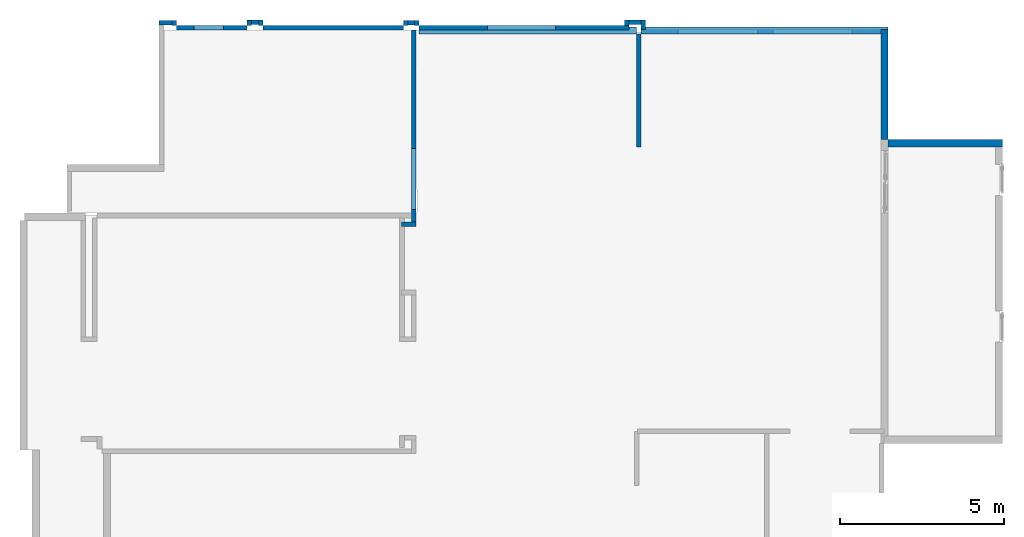
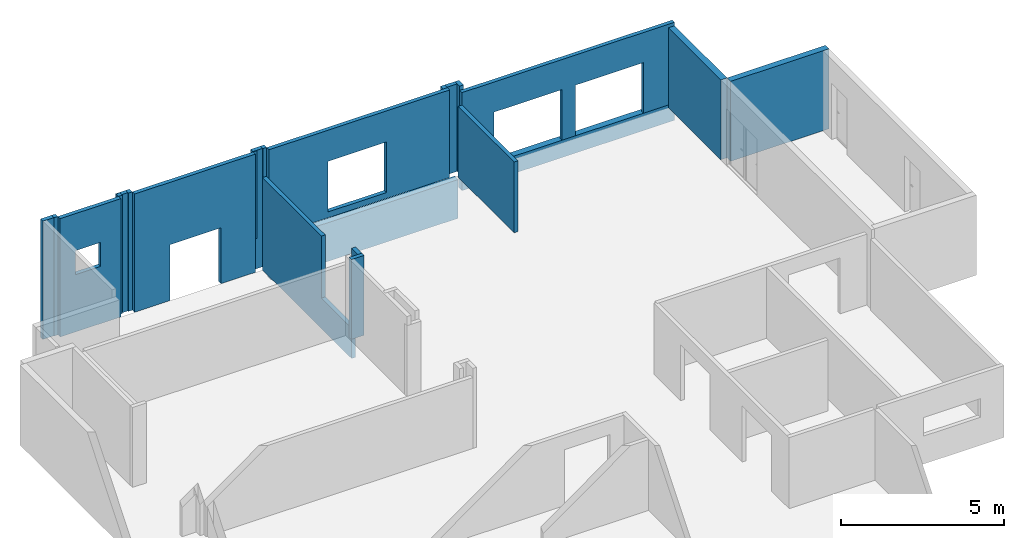
# One storey, part 3 of 4: 23 walls, 6 openings.
"""IFC4X3_ADD2 building model written with IfcOpenShell, lengths in millimetres."""

from ifc_helpers import new_model, entity, si_unit, converted_unit, frame, origin_with_axes, origin_2d_with_axis, place, context, subcontext, project, spatial, line, indexed_curve, outline, extrude, material, layer, layer_set, layer_usage, type_object, element, save


model = new_model("IFC4X3_ADD2")

# Units and contexts
model_context = context("Model", 3, precision=1e-05, world=origin_with_axes())
plan_context = context("Plan", 2, precision=1e-05, world=origin_2d_with_axis())
body_context = subcontext(model_context, "Body", "Model", "MODEL_VIEW")
ifc_project = project(units=[si_unit("VOLUMEUNIT", "CUBIC_METRE"), si_unit("LENGTHUNIT", "METRE", prefix="MILLI"), converted_unit("PLANEANGLEUNIT", "degree", entity("IfcReal", 0.0174532925199433), si_unit("PLANEANGLEUNIT", "RADIAN"), dimensions=[0, 0, 0, 0, 0, 0, 0]), si_unit("AREAUNIT", "SQUARE_METRE")], contexts=[model_context, plan_context])

# Site, building, storey
site_placement = place(None, origin_with_axes())
site = spatial("IfcSite", under=ifc_project, at=site_placement)
building_placement = place(site_placement, origin_with_axes())
building = spatial("IfcBuilding", under=site, at=building_placement, Name="Building")
storey_placement = place(building_placement, origin_with_axes())
storey = spatial("IfcBuildingStorey", under=building, at=storey_placement, Name="Storey")

# Walls
ifc_material_1 = material(Name="Clay_Brick_Red", Category="Bricks")
ifc_layer_1 = layer(ifc_material_1, 220.000015258789)
ifc_layer_set_1 = layer_set([ifc_layer_1])
ifc_layer_usage_1 = layer_usage(ifc_layer_set_1, "AXIS2", "POSITIVE", 0.0)
wall_type_1 = type_object("IfcWallType", Name="220mm_External", PredefinedType="STANDARD", material=ifc_layer_set_1)
wall_1_placement = place(storey_placement, frame((30176.3038635254, 36062.7861022949, 1145.0001001358), z_axis=(0.0, 0.0, 1.0), x_axis=(-0.999999999999098, -1.34308868382383e-06, 0.0)))
element("IfcWall", 1, at=wall_1_placement, inside=storey, type_object=wall_type_1, material=ifc_layer_usage_1, Name="Wall", context=body_context, shape_type="SweptSolid", body=[
    extrude(outline(indexed_curve([(0.0, 0.0), (0.0, 220.000015258789), (3500.00023841858, 220.000015258789), (3500.00023841858, 0.0)], segments=[line(1, 2, 3, 4, 1)])), origin_with_axes(), (0.0, 0.0, 1.0), 3000.0),
])
ifc_layer_usage_2 = layer_usage(ifc_layer_set_1, "AXIS2", "POSITIVE", 0.0)
wall_2_placement = place(storey_placement, frame((26456.3007354736, 39429.7828674316, 1145.0001001358), z_axis=(0.0, 0.0, 1.0), x_axis=(1.5060094256097e-06, -0.999999999998866, 0.0)))
element("IfcWall", 2, at=wall_2_placement, inside=storey, type_object=wall_type_1, material=ifc_layer_usage_2, Name="Wall", context=body_context, shape_type="SweptSolid", body=[
    extrude(outline(indexed_curve([(0.0, 0.0), (0.0, 220.000015258789), (3367.00010299683, 220.000015258789), (3367.00010299683, 0.0)], segments=[line(1, 2, 3, 4, 1)])), origin_with_axes(), (0.0, 0.0, 1.0), 3000.0),
])

# Wall, openings
ifc_material_2 = material(Category="Plastic")
ifc_layer_2 = layer(ifc_material_2, 140.0)
ifc_layer_set_2 = layer_set([ifc_layer_2])
ifc_layer_usage_3 = layer_usage(ifc_layer_set_2, "AXIS2", "POSITIVE", 0.0)
wall_type_2 = type_object("IfcWallType", Name="RDP", PredefinedType="ELEMENTEDWALL", material=ifc_layer_set_2)
wall_3_placement = place(storey_placement, frame((19126.3027191162, 39289.7758483887, 1145.0001001358), z_axis=(0.0, 0.0, 1.0), x_axis=(0.999999999998799, 1.5497207641583e-06, 0.0)))
wall_3 = element("IfcWall", 3, at=wall_3_placement, inside=storey, type_object=wall_type_2, material=ifc_layer_usage_3, Name="Wall", context=body_context, shape_type="SweptSolid", body=[
    extrude(outline(indexed_curve([(0.0, 0.0), (0.0, 140.0), (7550.00019073486, 140.0), (7550.00019073486, 0.0)], segments=[line(1, 2, 3, 4, 1)])), origin_with_axes(), (0.0, 0.0, 1.0), 3130.00011444092),
])
opening_1_placement = place(wall_3_placement, frame((1150.00917958512, 11707.9945862292, -1045.00009864569), z_axis=(0.0, 0.0, 1.0), x_axis=(0.999999999998799, -1.5497207641583e-06, 0.0)))
element("IfcOpeningElement", 4, at=opening_1_placement, cuts=wall_3, PredefinedType="OPENING", context=body_context, shape_type="SweptSolid", body=[
    extrude(outline(indexed_curve([(0.0, 499.999877929688), (2410.0, 499.999877929688), (2410.0, 0.0), (0.0, 0.0), (0.0, 499.999877929688)])), frame((0.00905990600585938, -11957.9925537109, 1145.0001001358), z_axis=(0.0, 0.0, 1.0), x_axis=(1.0, 0.0, 0.0)), (0.0, 0.0, 1.0), 1900.00012207031),
])
opening_2_placement = place(wall_3_placement, frame((4043.0088286295, 11707.9901028875, -1045.00009864569), z_axis=(0.0, 0.0, 1.0), x_axis=(0.999999999998799, -1.5497207641583e-06, 0.0)))
element("IfcOpeningElement", 5, at=opening_2_placement, cuts=wall_3, PredefinedType="OPENING", context=body_context, shape_type="SweptSolid", body=[
    extrude(outline(indexed_curve([(0.0, 499.999877929688), (2410.0, 499.999877929688), (2410.0, 0.0), (0.0, 0.0), (0.0, 499.999877929688)])), frame((0.00905990600585938, -11957.9925537109, 1145.0001001358), z_axis=(0.0, 0.0, 1.0), x_axis=(1.0, 0.0, 0.0)), (0.0, 0.0, 1.0), 1900.00012207031),
])

# Walls
ifc_layer_usage_4 = layer_usage(ifc_layer_set_2, "AXIS2", "POSITIVE", 0.0)
wall_4_placement = place(storey_placement, frame((19266.3173675537, 39429.7752380371, 1145.0001001358), z_axis=(0.0, 0.0, 1.0), x_axis=(-1.47422281315652e-06, 0.999999999998913, 0.0)))
element("IfcWall", 6, at=wall_4_placement, inside=storey, type_object=wall_type_2, material=ifc_layer_usage_4, Name="Wall", context=body_context, shape_type="SweptSolid", body=[
    extrude(outline(indexed_curve([(0.0, 0.0), (0.0, 140.0), (290.000021457672, 140.0), (290.000021457672, 0.0)], segments=[line(1, 2, 3, 4, 1)])), origin_with_axes(), (0.0, 0.0, 1.0), 3287.00017929077),
])
ifc_layer_usage_5 = layer_usage(ifc_layer_set_2, "AXIS2", "POSITIVE", 0.0)
wall_5_placement = place(storey_placement, frame((19126.3027191162, 39719.7761535645, 1145.0001001358), z_axis=(0.0, 0.0, 1.0), x_axis=(-0.999999999998344, -1.81992584202516e-06, 0.0)))
element("IfcWall", 7, at=wall_5_placement, inside=storey, type_object=wall_type_2, material=ifc_layer_usage_5, Name="Wall", context=body_context, shape_type="SweptSolid", body=[
    extrude(outline(indexed_curve([(0.0, 0.0), (0.0, 140.0), (503.000020980835, 140.0), (503.000020980835, 0.0)], segments=[line(1, 2, 3, 4, 1)])), origin_with_axes(), (0.0, 0.0, 1.0), 3287.00017929077),
])
ifc_layer_usage_6 = layer_usage(ifc_layer_set_2, "AXIS2", "POSITIVE", 0.0)
wall_6_placement = place(storey_placement, frame((18763.3037567139, 39549.7779846191, 1145.0001001358), z_axis=(0.0, 0.0, 1.0), x_axis=(-1.47422281315652e-06, 0.999999999998913, 0.0)))
element("IfcWall", 8, at=wall_6_placement, inside=storey, type_object=wall_type_2, material=ifc_layer_usage_6, Name="Wall", context=body_context, shape_type="SweptSolid", body=[
    extrude(outline(indexed_curve([(0.0, 0.0), (0.0, 140.0), (170.000001788139, 140.0), (170.000001788139, 0.0)], segments=[line(1, 2, 3, 4, 1)])), origin_with_axes(), (0.0, 0.0, 1.0), 3287.00017929077),
])

# Wall, opening
ifc_layer_usage_7 = layer_usage(ifc_layer_set_2, "AXIS2", "POSITIVE", 0.0)
wall_7_placement = place(storey_placement, frame((18763.3037567139, 39549.7779846191, 1145.0001001358), z_axis=(0.0, 0.0, 1.0), x_axis=(-0.999999999998344, -1.81992584202516e-06, 0.0)))
wall_7 = element("IfcWall", 9, at=wall_7_placement, inside=storey, type_object=wall_type_2, material=ifc_layer_usage_7, Name="Wall", context=body_context, shape_type="SweptSolid", body=[
    extrude(outline(indexed_curve([(0.0, 0.0), (0.0, 140.0), (6413.00010681152, 140.0), (6413.00010681152, 0.0)], segments=[line(1, 2, 3, 4, 1)])), origin_with_axes(), (0.0, 0.0, 1.0), 3287.00017929077),
])
opening_3_placement = place(wall_7_placement, frame((4324.0005592646, 250.0038496215, 220.000013709068), z_axis=(0.0, 0.0, 1.0), x_axis=(-0.999999999998458, 1.75635284449256e-06, 0.0)))
element("IfcOpeningElement", 10, at=opening_3_placement, cuts=wall_7, PredefinedType="OPENING", context=body_context, shape_type="SweptSolid", body=[
    extrude(outline(indexed_curve([(0.0, 0.0), (2079.15673828125, 0.0), (2079.15673828125, 499.999908447266), (0.0, 499.999908447266), (0.0, 0.0)])), origin_with_axes(), (0.0, 0.0, 1.0), 1900.00012207031),
])

# Walls
ifc_layer_usage_8 = layer_usage(ifc_layer_set_2, "AXIS2", "POSITIVE", 0.0)
wall_8_placement = place(storey_placement, frame((12210.3033065796, 39699.7680664062, 0.0), z_axis=(0.0, 0.0, 1.0), x_axis=(2.34047433877363e-06, -0.999999999997261, 0.0)))
element("IfcWall", 11, at=wall_8_placement, inside=storey, type_object=wall_type_2, material=ifc_layer_usage_8, Name="Wall", context=body_context, shape_type="SweptSolid", body=[
    extrude(outline(indexed_curve([(0.0, 0.0), (0.0, 140.0), (150.000005960464, 140.0), (150.000005960464, 0.0)], segments=[line(1, 2, 3, 4, 1)])), origin_with_axes(), (0.0, 0.0, 1.0), 4440.00005722046),
])
ifc_layer_usage_9 = layer_usage(ifc_layer_set_2, "AXIS2", "POSITIVE", 0.0)
wall_9_placement = place(storey_placement, frame((11868.3032989502, 39559.7686767578, 0.0), z_axis=(0.0, 0.0, 1.0), x_axis=(0.999999999997698, 2.14576721190912e-06, 0.0)))
element("IfcWall", 12, at=wall_9_placement, inside=storey, type_object=wall_type_2, material=ifc_layer_usage_9, Name="Wall", context=body_context, shape_type="SweptSolid", body=[
    extrude(outline(indexed_curve([(0.0, 0.0), (0.0, 140.0), (482.000023126602, 140.0), (482.000023126602, 0.0)], segments=[line(1, 2, 3, 4, 1)])), origin_with_axes(), (0.0, 0.0, 1.0), 4440.00005722046),
])
ifc_layer_usage_10 = layer_usage(ifc_layer_set_2, "AXIS2", "POSITIVE", 0.0)
wall_10_placement = place(storey_placement, frame((12008.3036422729, 39549.7665405273, 1145.0001001358), z_axis=(0.0, 0.0, 1.0), x_axis=(-2.1894786641444e-06, 0.999999999997603, 0.0)))
element("IfcWall", 13, at=wall_10_placement, inside=storey, type_object=wall_type_2, material=ifc_layer_usage_10, Name="Wall", context=body_context, shape_type="SweptSolid", body=[
    extrude(outline(indexed_curve([(0.0, 0.0), (0.0, 140.0), (150.000005960464, 140.0), (150.000005960464, 0.0)], segments=[line(1, 2, 3, 4, 1)])), origin_with_axes(), (0.0, 0.0, 1.0), 3287.00017929077),
])

# Wall, opening
ifc_layer_usage_11 = layer_usage(ifc_layer_set_2, "AXIS2", "POSITIVE", 0.0)
wall_11_placement = place(storey_placement, frame((11868.3032989502, 39549.7665405273, 0.0), z_axis=(0.0, 0.0, 1.0), x_axis=(-0.999999999996787, -2.53518169301155e-06, 0.0)))
wall_11 = element("IfcWall", 14, at=wall_11_placement, inside=storey, type_object=wall_type_2, material=ifc_layer_usage_11, Name="Wall", context=body_context, shape_type="SweptSolid", body=[
    extrude(outline(indexed_curve([(0.0, 0.0), (0.0, 140.0), (4290.00043869019, 140.0), (4290.00043869019, 0.0)], segments=[line(1, 2, 3, 4, 1)])), origin_with_axes(), (0.0, 0.0, 1.0), 4440.00005722046),
])
opening_4_placement = place(wall_11_placement, frame((3025.00027420041, 0.0039674755072383, 0.0), z_axis=(0.0, 0.0, 1.0), x_axis=(-0.999999999996946, 2.47160846810557e-06, 0.0)))
element("IfcOpeningElement", 15, at=opening_4_placement, cuts=wall_11, PredefinedType="OPENING", context=body_context, shape_type="SweptSolid", body=[
    extrude(outline(indexed_curve([(0.0, 0.0), (1799.99987792969, 0.0), (1799.99987792969, 499.999908447266), (0.0, 499.999908447266), (0.0, 0.0)])), frame((0.0, -250.0, 0.0), z_axis=(0.0, 0.0, 1.0), x_axis=(1.0, 0.0, 0.0)), (0.0, 0.0, 1.0), 2100.00024414062),
])

# Walls
ifc_layer_usage_12 = layer_usage(ifc_layer_set_2, "AXIS2", "POSITIVE", 0.0)
wall_12_placement = place(storey_placement, frame((7438.30299377441, 39719.7532653809, 0.0), z_axis=(0.0, 0.0, 1.0), x_axis=(2.69810220742256e-06, -0.99999999999636, 0.0)))
element("IfcWall", 16, at=wall_12_placement, inside=storey, type_object=wall_type_2, material=ifc_layer_usage_12, Name="Wall", context=body_context, shape_type="SweptSolid", body=[
    extrude(outline(indexed_curve([(0.0, 0.0), (0.0, 140.0), (170.000001788139, 140.0), (170.000001788139, 0.0)], segments=[line(1, 2, 3, 4, 1)])), origin_with_axes(), (0.0, 0.0, 1.0), 4440.00005722046),
])
ifc_layer_usage_13 = layer_usage(ifc_layer_set_2, "AXIS2", "POSITIVE", 0.0)
wall_13_placement = place(storey_placement, frame((7088.303565979, 39579.7500610352, 0.0), z_axis=(0.0, 0.0, 1.0), x_axis=(0.999999999996241, 2.74181365965766e-06, 0.0)))
element("IfcWall", 17, at=wall_13_placement, inside=storey, type_object=wall_type_2, material=ifc_layer_usage_13, Name="Wall", context=body_context, shape_type="SweptSolid", body=[
    extrude(outline(indexed_curve([(0.0, 0.0), (0.0, 140.0), (490.000009536743, 140.0), (490.000009536743, 0.0)], segments=[line(1, 2, 3, 4, 1)])), origin_with_axes(), (0.0, 0.0, 1.0), 4440.00005722046),
])
ifc_layer_usage_14 = layer_usage(ifc_layer_set_2, "AXIS2", "POSITIVE", 0.0)
wall_14_placement = place(storey_placement, frame((7228.30390930176, 39549.7550964355, 0.0), z_axis=(0.0, 0.0, 1.0), x_axis=(-2.66631582234329e-06, 0.999999999996446, 0.0)))
element("IfcWall", 18, at=wall_14_placement, inside=storey, type_object=wall_type_2, material=ifc_layer_usage_14, Name="Wall", context=body_context, shape_type="SweptSolid", body=[
    extrude(outline(indexed_curve([(0.0, 0.0), (0.0, 140.0), (151.000007987022, 140.0), (151.000007987022, 0.0)], segments=[line(1, 2, 3, 4, 1)])), origin_with_axes(), (0.0, 0.0, 1.0), 4440.00005722046),
])

# Wall, opening
ifc_layer_usage_15 = layer_usage(ifc_layer_set_2, "AXIS2", "POSITIVE", 0.0)
wall_15_placement = place(storey_placement, frame((7088.30261230469, 39549.7550964355, 0.0), z_axis=(0.0, 0.0, 1.0), x_axis=(-0.999999999995464, -3.01201885120916e-06, 0.0)))
wall_15 = element("IfcWall", 19, at=wall_15_placement, inside=storey, type_object=wall_type_2, material=ifc_layer_usage_15, Name="Wall", context=body_context, shape_type="SweptSolid", body=[
    extrude(outline(indexed_curve([(0.0, 0.0), (0.0, 140.0), (2152.00018882751, 140.0), (2152.00018882751, 0.0)], segments=[line(1, 2, 3, 4, 1)])), origin_with_axes(), (0.0, 0.0, 1.0), 4440.00005722046),
])
opening_5_placement = place(wall_15_placement, frame((1252.00059216996, 250.003937939951, 2150.00009536743), z_axis=(0.0, 0.0, 1.0), x_axis=(-0.999999999995653, 2.94844562630343e-06, 0.0)))
element("IfcOpeningElement", 20, at=opening_5_placement, cuts=wall_15, PredefinedType="OPENING", context=body_context, shape_type="SweptSolid", body=[
    extrude(outline(indexed_curve([(0.0, 499.999938964844), (899.999938964844, 499.999938964844), (899.999938964844, 0.0), (0.0, 0.0), (0.0, 499.999938964844)])), frame((-363.324165344238, 0.0, 0.0), z_axis=(0.0, 0.0, 1.0), x_axis=(1.0, 0.0, 0.0)), (0.0, 0.0, 1.0), 900.000061035156),
])

# Walls
ifc_layer_usage_16 = layer_usage(ifc_layer_set_2, "AXIS2", "POSITIVE", 0.0)
wall_16_placement = place(storey_placement, frame((4936.30313873291, 39549.7550964355, 0.0), z_axis=(0.0, 0.0, 1.0), x_axis=(-2.66631582234329e-06, 0.999999999996446, 0.0)))
element("IfcWall", 21, at=wall_16_placement, inside=storey, type_object=wall_type_2, material=ifc_layer_usage_16, Name="Wall", context=body_context, shape_type="SweptSolid", body=[
    extrude(outline(indexed_curve([(0.0, 0.0), (0.0, 140.0), (151.000007987022, 140.0), (151.000007987022, 0.0)], segments=[line(1, 2, 3, 4, 1)])), origin_with_axes(), (0.0, 0.0, 1.0), 4440.00005722046),
])
ifc_layer_usage_17 = layer_usage(ifc_layer_set_2, "AXIS2", "POSITIVE", 0.0)
wall_17_placement = place(storey_placement, frame((4936.30313873291, 39700.756072998, 0.0), z_axis=(0.0, 0.0, 1.0), x_axis=(-0.999999999995464, -3.01201885120916e-06, 0.0)))
element("IfcWall", 22, at=wall_17_placement, inside=storey, type_object=wall_type_2, material=ifc_layer_usage_17, Name="Wall", context=body_context, shape_type="SweptSolid", body=[
    extrude(outline(indexed_curve([(0.0, 0.0), (0.0, 140.0), (529.000043869019, 140.0), (529.000043869019, 0.0)], segments=[line(1, 2, 3, 4, 1)])), origin_with_axes(), (0.0, 0.0, 1.0), 4440.00005722046),
])

# Wall, opening
ifc_layer_usage_18 = layer_usage(ifc_layer_set_2, "AXIS2", "POSITIVE", 0.0)
wall_18_placement = place(storey_placement, frame((12117.057800293, 39409.7557067871, 0.836849212646484), z_axis=(0.0, 0.0, 1.0), x_axis=(3.53256723426581e-06, -0.999999999993761, 0.0)))
wall_18 = element("IfcWall", 23, at=wall_18_placement, inside=storey, type_object=wall_type_2, material=ifc_layer_usage_18, Name="Wall", context=body_context, shape_type="SweptSolid", body=[
    extrude(outline(indexed_curve([(0.0, 0.0), (0.0, 140.0), (5480.00049591064, 140.0), (5480.00049591064, 0.0)], segments=[line(1, 2, 3, 4, 1)])), origin_with_axes(), (0.0, 0.0, 1.0), 3470.00026702881),
])
opening_6_placement = place(wall_18_placement, frame((5592.99779815775, -200.000672234754, 0.0), z_axis=(0.0, 0.0, 1.0), x_axis=(3.53256723426581e-06, 0.99999999999376, 0.0)))
element("IfcOpeningElement", 24, at=opening_6_placement, cuts=wall_18, PredefinedType="OPENING", context=body_context, shape_type="SweptSolid", body=[
    extrude(outline(indexed_curve([(0.0, 0.0), (499.999908447266, 0.0), (499.999908447266, 1969.99987792969), (0.0, 1969.99987792969), (0.0, 0.0)])), frame((0.0, 0.0, 1145.0001001358), z_axis=(0.0, 0.0, 1.0), x_axis=(1.0, 0.0, 0.0)), (0.0, 0.0, 1.0), 3000.00024414062),
])

# Walls
ifc_layer_usage_19 = layer_usage(ifc_layer_set_2, "AXIS2", "POSITIVE", 0.0)
wall_19_placement = place(storey_placement, frame((12117.057800293, 33929.7561645508, 1145.0001001358), z_axis=(0.0, 0.0, 1.0), x_axis=(3.53256723426581e-06, -0.999999999993761, 0.0)))
element("IfcWall", 25, at=wall_19_placement, inside=storey, type_object=wall_type_2, material=ifc_layer_usage_19, Name="Wall", context=body_context, shape_type="SweptSolid", body=[
    extrude(outline(indexed_curve([(0.0, 0.0), (0.0, 140.0), (527.00001001358, 140.0), (527.00001001358, 0.0)], segments=[line(1, 2, 3, 4, 1)])), origin_with_axes(), (0.0, 0.0, 1.0), 3000.0),
])
ifc_layer_usage_20 = layer_usage(ifc_layer_set_2, "AXIS2", "POSITIVE", 0.0)
wall_20_placement = place(storey_placement, frame((11807.0602416992, 33402.7557373047, 1145.0001001358), z_axis=(0.0, 0.0, 1.0), x_axis=(0.999999999993605, 3.57627868650057e-06, 0.0)))
element("IfcWall", 26, at=wall_20_placement, inside=storey, type_object=wall_type_2, material=ifc_layer_usage_20, Name="Wall", context=body_context, shape_type="SweptSolid", body=[
    extrude(outline(indexed_curve([(0.0, 0.0), (0.0, 140.0), (450.000017881393, 140.0), (450.000017881393, 0.0)], segments=[line(1, 2, 3, 4, 1)])), origin_with_axes(), (0.0, 0.0, 1.0), 3000.0),
])
ifc_layer_usage_21 = layer_usage(ifc_layer_set_2, "AXIS2", "NEGATIVE", 0.0)
wall_21_placement = place(storey_placement, frame((19136.302947998, 39289.7758483887, 1145.0001001358), z_axis=(0.0, 0.0, 1.0), x_axis=(1.5060094256097e-06, -0.999999999998866, 0.0)))
element("IfcWall", 27, at=wall_21_placement, inside=storey, type_object=wall_type_2, material=ifc_layer_usage_21, Name="Wall", context=body_context, shape_type="SweptSolid", body=[
    extrude(outline(indexed_curve([(0.0, -140.0), (0.0, 0.0), (3443.00007820129, 0.0), (3443.00007820129, -140.0)], segments=[line(1, 2, 3, 4, 1)])), origin_with_axes(), (0.0, 0.0, 1.0), 2660.00008583069),
])
ifc_material_3 = material(Name="NFX-Clay", Category="Clay Bricks")
ifc_layer_3 = layer(ifc_material_3, 220.000015258789)
ifc_layer_set_3 = layer_set([ifc_layer_3])
ifc_layer_usage_22 = layer_usage(ifc_layer_set_3, "AXIS2", "POSITIVE", 0.0)
wall_type_3 = type_object("IfcWallType", Name="220mm_Plinth", PredefinedType="STANDARD", material=ifc_layer_set_3)
wall_22_placement = place(storey_placement, frame((19126.3027191162, 39289.7758483887, 595.000028610229), z_axis=(0.0, 0.0, 1.0), x_axis=(0.999999999998799, 1.5497207641583e-06, 0.0)))
element("IfcWall", 28, at=wall_22_placement, inside=storey, type_object=wall_type_3, material=ifc_layer_usage_22, Name="Wall", context=body_context, shape_type="SweptSolid", body=[
    extrude(outline(indexed_curve([(0.0, 0.0), (0.0, 220.000015258789), (7550.00019073486, 220.000015258789), (7550.00019073486, 0.0)], segments=[line(1, 2, 3, 4, 1)])), origin_with_axes(), (0.0, 0.0, 1.0), 650.000035762787),
])
ifc_layer_usage_23 = layer_usage(ifc_layer_set_3, "AXIS2", "POSITIVE", 0.0)
wall_23_placement = place(storey_placement, frame((12350.3036499023, 39289.7758483887, -394.000053405762), z_axis=(0.0, 0.0, 1.0), x_axis=(0.999999999998799, 1.5497207641583e-06, 0.0)))
element("IfcWall", 29, at=wall_23_placement, inside=storey, type_object=wall_type_3, material=ifc_layer_usage_23, Name="Wall", context=body_context, shape_type="SweptSolid", body=[
    extrude(outline(indexed_curve([(0.0, 0.0), (0.0, 220.000015258789), (6645.99835403019, 220.000015258789), (6645.9983444137, 0.0)], segments=[line(1, 2, 3, 4, 1)])), origin_with_axes(), (0.0, 0.0, 1.0), 1454.00011539459),
])

save(model, "model.ifc")
